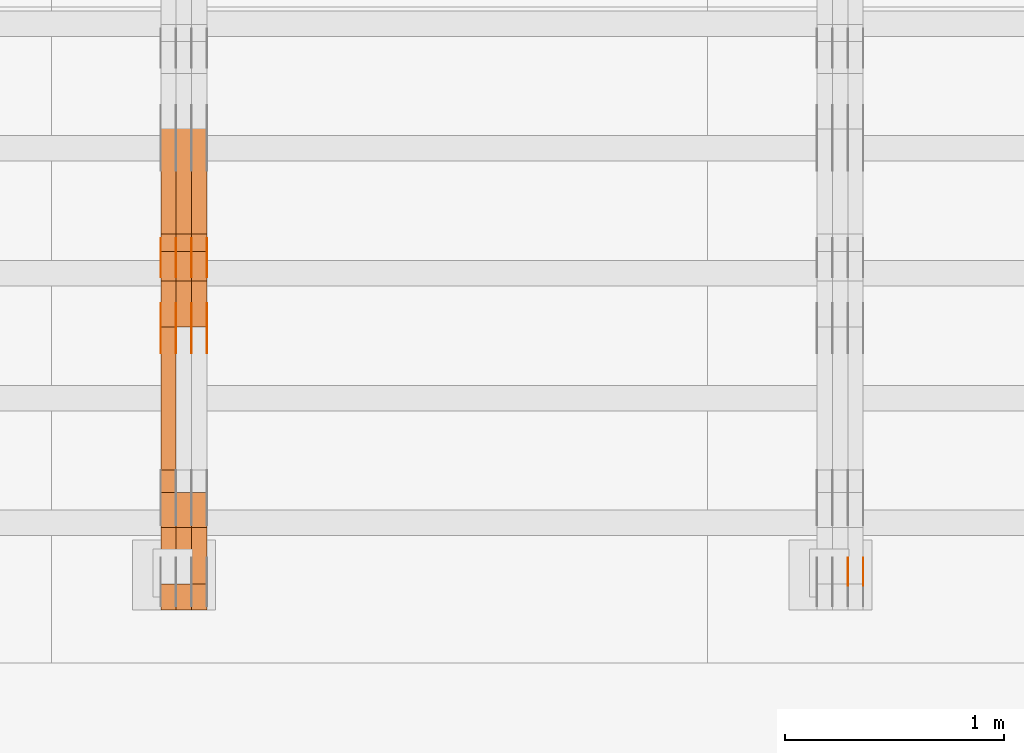
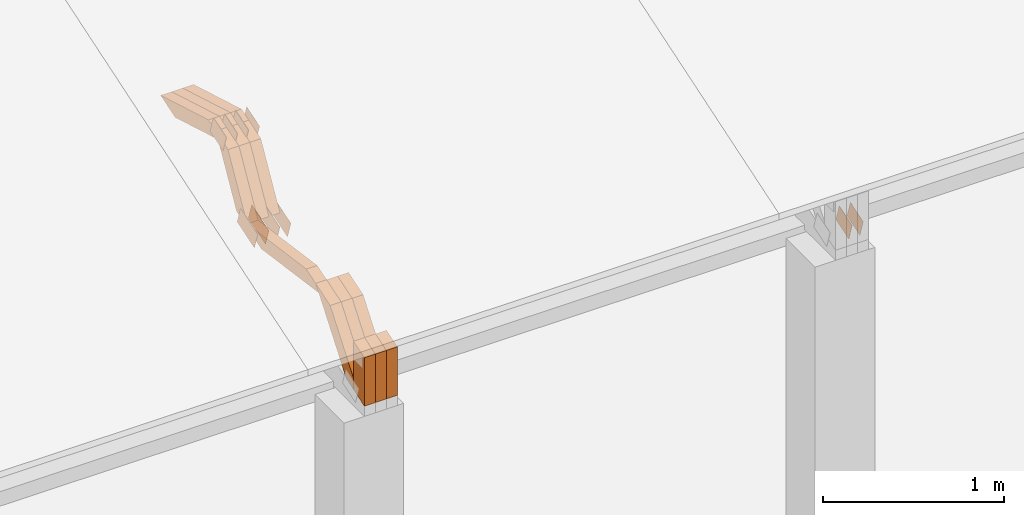
# One storey, part 247 of 385: 28 proxies.
"""IFC2X3 building model written with IfcOpenShell, lengths in millimetres."""

import ifcopenshell
import ifcopenshell.guid

model = None  # the IFC model being written
_history = None  # IfcOwnerHistory: only IFC2X3 demands one
_inside = {}  # id of a spatial element -> (the spatial element, [elements in it])
_under = {}  # id of a project, library or spatial element -> (it, [spatial elements below it])
_declared = {}  # id of a project -> (the project, [libraries it declares])
_typed = {}  # id of a type object -> (the type object, [elements of that type])
_made_of = {}  # id of a material, layer set ... -> (it, [elements and type objects made of it])


def new_model(schema):
    """Start an empty IFC model of exactly this schema.

    Asked for "IFC4X3", IfcOpenShell would pick the latest addendum, in which some entities
    have other attributes; the version numbers below select the first issue.
    IFC2X3 requires an IfcOwnerHistory on every rooted entity: one is made here for all.
    """
    global model, _history
    if schema == "IFC4X3":
        model = ifcopenshell.file(schema_version=(4, 3, 0, 0))
    else:
        model = ifcopenshell.file(schema=schema)
    _inside.clear()
    _under.clear()
    _declared.clear()
    _typed.clear()
    _made_of.clear()
    _history = None
    if model.schema == "IFC2X3":
        org = make("IfcOrganization", Name="unknown")
        user = make(
            "IfcPersonAndOrganization",
            ThePerson=make("IfcPerson", FamilyName="unknown"),
            TheOrganization=org,
        )
        app = make(
            "IfcApplication",
            ApplicationDeveloper=org,
            Version="unknown",
            ApplicationFullName="unknown",
            ApplicationIdentifier="unknown",
        )
        _history = make(
            "IfcOwnerHistory",
            OwningUser=user,
            OwningApplication=app,
            ChangeAction="ADDED",
            CreationDate=0,
        )
    return model


def make(cls, **values):
    """One entity of the class cls with the attributes given. An attribute that is None is left unset."""
    return model.create_entity(
        cls, **{name: value for name, value in values.items() if value is not None}
    )


def entity(cls, *values):
    """Any entity or typed value of the class cls, its attributes in the order of the schema. None: left unset."""
    e = model.create_entity(cls)
    for i, value in enumerate(values):
        if value is not None:
            e[i] = value
    return e


def rooted(cls, **values):
    """An entity with a GlobalId (a new one), such as an element, a storey or a relation."""
    return make(cls, GlobalId=ifcopenshell.guid.new(), OwnerHistory=_history, **values)


def si_unit(unit_type, name, prefix=None):
    """IfcSIUnit, for example si_unit("LENGTHUNIT", "METRE", prefix="MILLI")."""
    return make("IfcSIUnit", UnitType=unit_type, Prefix=prefix, Name=name)


def converted_unit(unit_type, name, factor, base, dimensions=None, offset=None):
    """IfcConversionBasedUnit, such as the inch: factor (a typed value) times the base unit."""
    return make(
        "IfcConversionBasedUnit"
        if offset is None
        else "IfcConversionBasedUnitWithOffset",
        ConversionOffset=offset,
        Dimensions=None
        if dimensions is None
        else entity("IfcDimensionalExponents", *dimensions),
        UnitType=unit_type,
        Name=name,
        ConversionFactor=make(
            "IfcMeasureWithUnit", ValueComponent=factor, UnitComponent=base
        ),
    )


def derived_unit(unit_type, elements):
    """IfcDerivedUnit: a product of units, each with its exponent."""
    return make(
        "IfcDerivedUnit",
        Elements=[
            make("IfcDerivedUnitElement", Unit=unit, Exponent=power)
            for unit, power in elements
        ],
        UnitType=unit_type,
    )


def assignment(units):
    """IfcUnitAssignment: the units of a project."""
    return None if units is None else make("IfcUnitAssignment", Units=units)


def point(xyz):
    """IfcCartesianPoint."""
    return None if xyz is None else make("IfcCartesianPoint", Coordinates=xyz)


def direction(xyz):
    """IfcDirection."""
    return None if xyz is None else make("IfcDirection", DirectionRatios=xyz)


def frame(location, z_axis=None, x_axis=None):
    """IfcAxis2Placement3D, a coordinate frame: its origin and axes. An axis left out is left unset."""
    return make(
        "IfcAxis2Placement3D",
        Location=point(location),
        Axis=direction(z_axis),
        RefDirection=direction(x_axis),
    )


def origin():
    """The frame at (0, 0, 0) with its axes left unset."""
    return frame((0.0, 0.0, 0.0))


def place(relative_to, where):
    """IfcLocalPlacement: puts the frame where relative to a parent placement (None: the world)."""
    return make(
        "IfcLocalPlacement", PlacementRelTo=relative_to, RelativePlacement=where
    )


def context(
    kind, dimensions, precision=None, world=None, true_north=None, identifier=None
):
    """IfcGeometricRepresentationContext, for example the 3D "Model" context."""
    return make(
        "IfcGeometricRepresentationContext",
        ContextIdentifier=identifier,
        ContextType=kind,
        CoordinateSpaceDimension=dimensions,
        Precision=precision,
        WorldCoordinateSystem=world,
        TrueNorth=true_north,
    )


def subcontext(parent, identifier, kind, view, scale=None):
    """IfcGeometricRepresentationSubContext, for example "Body" below "Model"."""
    return make(
        "IfcGeometricRepresentationSubContext",
        ContextIdentifier=identifier,
        ContextType=kind,
        ParentContext=parent,
        TargetScale=scale,
        TargetView=view,
    )


def project(units=None, contexts=None):
    """IfcProject with its units and contexts."""
    return rooted(
        "IfcProject",
        Name="project",
        RepresentationContexts=contexts,
        UnitsInContext=assignment(units),
    )


def spatial(cls, under=None, at=None, **own):
    """A site, building, storey or space (cls), placed at a placement, below another one or the project."""
    s = rooted(cls, ObjectPlacement=at, **own)
    if under is not None:
        _under.setdefault(under.id(), (under, []))[1].append(s)
    return s


def polyline(points):
    """IfcPolyline through the points."""
    return make("IfcPolyline", Points=[point(p) for p in points])


def outline(outer, holes=None, kind="AREA"):
    """IfcArbitraryClosedProfileDef: a profile drawn as a closed curve; with holes, ...WithVoids."""
    if holes is None:
        return make("IfcArbitraryClosedProfileDef", ProfileType=kind, OuterCurve=outer)
    return make(
        "IfcArbitraryProfileDefWithVoids",
        ProfileType=kind,
        OuterCurve=outer,
        InnerCurves=holes,
    )


def extrude(swept, where, along, depth):
    """IfcExtrudedAreaSolid: the profile swept, set in the frame where, extruded along a direction by depth."""
    return make(
        "IfcExtrudedAreaSolid",
        SweptArea=swept,
        Position=where,
        ExtrudedDirection=direction(along),
        Depth=depth,
    )


def shape(context_of_items, identifier, shape_type, items):
    """IfcShapeRepresentation: the items that make up one representation, for example the "Body"."""
    return make(
        "IfcShapeRepresentation",
        ContextOfItems=context_of_items,
        RepresentationIdentifier=identifier,
        RepresentationType=shape_type,
        Items=items,
    )


def source(mapping_origin, context_of_items, identifier, shape_type, items):
    """IfcRepresentationMap: a shape defined once, which mapped items show again and again."""
    return make(
        "IfcRepresentationMap",
        MappingOrigin=mapping_origin,
        MappedRepresentation=shape(context_of_items, identifier, shape_type, items),
    )


def transform(
    local_origin,
    x_axis=None,
    y_axis=None,
    z_axis=None,
    scale=None,
    scale2=None,
    scale3=None,
    uniform=True,
):
    """IfcCartesianTransformationOperator3D, or its non-uniform kind. x_axis, y_axis, z_axis: its Axis1, 2, 3."""
    if uniform:
        return make(
            "IfcCartesianTransformationOperator3D",
            Axis1=direction(x_axis),
            Axis2=direction(y_axis),
            LocalOrigin=point(local_origin),
            Scale=scale,
            Axis3=direction(z_axis),
        )
    return make(
        "IfcCartesianTransformationOperator3DnonUniform",
        Axis1=direction(x_axis),
        Axis2=direction(y_axis),
        LocalOrigin=point(local_origin),
        Scale=scale,
        Axis3=direction(z_axis),
        Scale2=scale2,
        Scale3=scale3,
    )


def mapped(mapping_source, mapping_target):
    """IfcMappedItem: shows the shape of a source again, moved by a transform."""
    return make(
        "IfcMappedItem", MappingSource=mapping_source, MappingTarget=mapping_target
    )


def material(Name=None, Category=None):
    """IfcMaterial."""
    return make("IfcMaterial", Name=Name, Category=Category)


def made_of(thing, what):
    """Note that an element or type object is made of a material, layer set ...; save() writes the relation."""
    if what is not None:
        _made_of.setdefault(what.id(), (what, []))[1].append(thing)
    return thing


def type_object(cls, material=None, **own):
    """A type object (cls), such as IfcWallType, which elements share."""
    return made_of(rooted(cls, **own), material)


def type_shapes(of_type, sources):
    """Give a type object the sources (RepresentationMaps) that its elements show as mapped items."""
    of_type.RepresentationMaps = sources


def element(
    cls,
    number,
    at=None,
    inside=None,
    cuts=None,
    type_object=None,
    material=None,
    context=None,
    identifier="Body",
    shape_type=None,
    held_by="IfcProductDefinitionShape",
    body=None,
    shapes=None,
    **own,
):
    """One element of the class cls, such as IfcWall. Its Tag is "e" and its number.

    at: its placement. inside: the storey or other place that contains it. cuts: it is an
    opening in that element (IfcRelVoidsElement). A single representation is given by context,
    identifier, shape_type and body (its items); several are given by shapes. held_by: the class
    of the entity that holds the representations. save() writes the other relations.
    """
    e = rooted(cls, Tag="e%d" % number, ObjectPlacement=at, **own)
    if body is not None:
        shapes = [shape(context, identifier, shape_type, body)]
    if shapes is not None:
        e.Representation = make(held_by, Representations=shapes)
    if inside is not None:
        _inside.setdefault(inside.id(), (inside, []))[1].append(e)
    if cuts is not None:
        rooted(
            "IfcRelVoidsElement", RelatingBuildingElement=cuts, RelatedOpeningElement=e
        )
    if type_object is not None:
        _typed.setdefault(type_object.id(), (type_object, []))[1].append(e)
    return made_of(e, material)


def aggregate(whole, parts):
    """IfcRelAggregates: a whole, such as a stair, and the parts it consists of."""
    return rooted("IfcRelAggregates", RelatingObject=whole, RelatedObjects=parts)


def save(model, path):
    """Write the relations noted so far, then the file.

    IfcRelAggregates (storeys below a building ...), IfcRelContainedInSpatialStructure (elements
    in a storey), IfcRelDefinesByType, IfcRelAssociatesMaterial and IfcRelDeclares: one each for
    every whole, place, type object, material and project.
    """
    for whole, parts in _under.values():
        aggregate(whole, parts)
    for where, things in _inside.values():
        rooted(
            "IfcRelContainedInSpatialStructure",
            RelatedElements=things,
            RelatingStructure=where,
        )
    for kind, things in _typed.values():
        rooted("IfcRelDefinesByType", RelatedObjects=things, RelatingType=kind)
    for what, things in _made_of.values():
        rooted("IfcRelAssociatesMaterial", RelatedObjects=things, RelatingMaterial=what)
    for by, libraries in _declared.values():
        rooted("IfcRelDeclares", RelatingContext=by, RelatedDefinitions=libraries)
    model.write(path)


model = new_model("IFC2X3")

# Units and contexts
model_context = context("Model", 3, precision=0.01, world=origin(), true_north=direction((6.12303176911189e-17, 1.0)))
body_context = subcontext(model_context, "Body", "Model", "MODEL_VIEW")
ifc_project = project(units=[si_unit("LENGTHUNIT", "METRE", prefix="MILLI"), si_unit("AREAUNIT", "SQUARE_METRE"), si_unit("VOLUMEUNIT", "CUBIC_METRE"), converted_unit("PLANEANGLEUNIT", "DEGREE", entity("IfcRatioMeasure", 0.0174532925199433), si_unit("PLANEANGLEUNIT", "RADIAN"), dimensions=[0, 0, 0, 0, 0, 0, 0]), si_unit("MASSUNIT", "GRAM", prefix="KILO"), derived_unit("MASSDENSITYUNIT", [(si_unit("MASSUNIT", "GRAM", prefix="KILO"), 1), (si_unit("LENGTHUNIT", "METRE"), -3)]), si_unit("TIMEUNIT", "SECOND"), si_unit("FREQUENCYUNIT", "HERTZ"), si_unit("THERMODYNAMICTEMPERATUREUNIT", "DEGREE_CELSIUS"), derived_unit("THERMALTRANSMITTANCEUNIT", [(si_unit("MASSUNIT", "GRAM", prefix="KILO"), 1), (si_unit("THERMODYNAMICTEMPERATUREUNIT", "KELVIN"), -1), (si_unit("TIMEUNIT", "SECOND"), -3)]), derived_unit("VOLUMETRICFLOWRATEUNIT", [(si_unit("LENGTHUNIT", "METRE"), 3), (si_unit("TIMEUNIT", "SECOND"), -1)]), si_unit("ELECTRICCURRENTUNIT", "AMPERE"), si_unit("ELECTRICVOLTAGEUNIT", "VOLT"), si_unit("POWERUNIT", "WATT"), si_unit("FORCEUNIT", "NEWTON", prefix="KILO"), si_unit("ILLUMINANCEUNIT", "LUX"), si_unit("LUMINOUSFLUXUNIT", "LUMEN"), si_unit("LUMINOUSINTENSITYUNIT", "CANDELA"), derived_unit("USERDEFINED", [(si_unit("MASSUNIT", "GRAM", prefix="KILO"), -1), (si_unit("LENGTHUNIT", "METRE"), -2), (si_unit("TIMEUNIT", "SECOND"), 3), (si_unit("LUMINOUSFLUXUNIT", "LUMEN"), 1)]), derived_unit("LINEARVELOCITYUNIT", [(si_unit("LENGTHUNIT", "METRE"), 1), (si_unit("TIMEUNIT", "SECOND"), -1)]), si_unit("PRESSUREUNIT", "PASCAL"), derived_unit("USERDEFINED", [(si_unit("LENGTHUNIT", "METRE"), -2), (si_unit("MASSUNIT", "GRAM", prefix="KILO"), 1), (si_unit("TIMEUNIT", "SECOND"), -2)])], contexts=[model_context])

# Site, building, storey
site_placement = place(None, origin())
site = spatial("IfcSite", under=ifc_project, at=site_placement, CompositionType="ELEMENT")
building_placement = place(site_placement, origin())
building = spatial("IfcBuilding", under=site, at=building_placement, CompositionType="ELEMENT")
storey_placement = place(building_placement, origin())
storey = spatial("IfcBuildingStorey", under=building, at=storey_placement, Name="Default", CompositionType="ELEMENT", Elevation=0.0)

# Proxies
ifc_material_1 = material(Name="IfcSurfaceStyle #477756")
building_element_proxy_type_1 = type_object("IfcBuildingElementProxyType", PredefinedType="NOTDEFINED", material=ifc_material_1)
shared_shape_1 = source(origin(), body_context, "Body", "SweptSolid", [
    extrude(outline(polyline([(-74.999865408764, -60.0000379172698), (74.9998729365771, -60.0000379172698), (74.9998642299588, 60.0000379172698), (-74.9998717577719, 60.0000379172698), (-74.999865408764, -60.0000379172698)])), frame((75.0005044383734, 60.0001679035349, 0.0), z_axis=(0.0, 0.0, 1.0), x_axis=(-1.0, 0.0, 0.0)), (0.0, 0.0, 1.0), 1.3),
])
type_shapes(building_element_proxy_type_1, [shared_shape_1])
proxy_1_placement = place(building_placement, frame((39386.3, 2998.66143710398, 150.423871180894), z_axis=(-1.0, 0.0, 0.0), x_axis=(0.0, 0.951056516295124, 0.309016994375039)))
element("IfcBuildingElementProxy", 1, at=proxy_1_placement, inside=storey, type_object=building_element_proxy_type_1, material=ifc_material_1, context=body_context, shape_type="MappedRepresentation", body=[
    mapped(shared_shape_1, transform((0.0, 0.0, 0.0), scale=1.0)),
])
ifc_material_2 = material(Name="IfcSurfaceStyle #477699")
building_element_proxy_type_2 = type_object("IfcBuildingElementProxyType", PredefinedType="NOTDEFINED", material=ifc_material_2)
shared_shape_2 = source(origin(), body_context, "Body", "SweptSolid", [
    extrude(outline(polyline([(-74.999865408764, -60.0000379172698), (74.9998729365771, -60.0000379172698), (74.9998642299588, 60.0000379172698), (-74.9998717577719, 60.0000379172698), (-74.999865408764, -60.0000379172698)])), frame((75.0005044383734, 60.0001679035349, 0.0), z_axis=(0.0, 0.0, 1.0), x_axis=(-1.0, 0.0, 0.0)), (0.0, 0.0, 1.0), 1.3),
])
type_shapes(building_element_proxy_type_2, [shared_shape_2])
proxy_2_placement = place(building_placement, frame((39315.0, 2998.66143710398, 150.423871180894), z_axis=(-1.0, 0.0, 0.0), x_axis=(0.0, 0.951056516295124, 0.309016994375039)))
element("IfcBuildingElementProxy", 2, at=proxy_2_placement, inside=storey, type_object=building_element_proxy_type_2, material=ifc_material_2, context=body_context, shape_type="MappedRepresentation", body=[
    mapped(shared_shape_2, transform((0.0, 0.0, 0.0), scale=1.0)),
])
ifc_material_3 = material(Name="IfcSurfaceStyle #477642")
building_element_proxy_type_3 = type_object("IfcBuildingElementProxyType", PredefinedType="NOTDEFINED", material=ifc_material_3)
shared_shape_3 = source(origin(), body_context, "Body", "SweptSolid", [
    extrude(outline(polyline([(-74.999865408764, -60.0000379172698), (74.9998729365771, -60.0000379172698), (74.9998642299588, 60.0000379172698), (-74.9998717577719, 60.0000379172698), (-74.999865408764, -60.0000379172698)])), frame((75.0005044383734, 60.0001679035349, 0.0), z_axis=(0.0, 0.0, 1.0), x_axis=(-1.0, 0.0, 0.0)), (0.0, 0.0, 1.0), 1.3),
])
type_shapes(building_element_proxy_type_3, [shared_shape_3])
proxy_3_placement = place(building_placement, frame((39316.3, 2998.66143710398, 150.423871180894), z_axis=(-1.0, 0.0, 0.0), x_axis=(0.0, 0.951056516295124, 0.309016994375039)))
element("IfcBuildingElementProxy", 3, at=proxy_3_placement, inside=storey, type_object=building_element_proxy_type_3, material=ifc_material_3, context=body_context, shape_type="MappedRepresentation", body=[
    mapped(shared_shape_3, transform((0.0, 0.0, 0.0), scale=1.0)),
])
ifc_material_4 = material(Name="IfcSurfaceStyle #442982")
building_element_proxy_type_4 = type_object("IfcBuildingElementProxyType", PredefinedType="NOTDEFINED", material=ifc_material_4)
shared_shape_4 = source(origin(), body_context, "Body", "SweptSolid", [
    extrude(outline(polyline([(-99.9998204243802, -60.000067376167), (99.9998338462265, -60.000067376167), (99.9998204243802, 60.000067376167), (-99.9998338462265, 60.000067376167), (-99.9998204243802, -60.000067376167)])), frame((100.000602015329, 60.0001864986889, 0.0), z_axis=(0.0, 0.0, 1.0), x_axis=(-1.0, 0.0, 0.0)), (0.0, 0.0, 1.0), 1.3),
])
type_shapes(building_element_proxy_type_4, [shared_shape_4])
proxy_4_placement = place(building_placement, frame((36386.3, 4114.85465165112, 513.097031388771), z_axis=(-1.0, 0.0, 0.0), x_axis=(0.0, 0.951056516295124, 0.309016994375039)))
element("IfcBuildingElementProxy", 4, at=proxy_4_placement, inside=storey, type_object=building_element_proxy_type_4, material=ifc_material_4, context=body_context, shape_type="MappedRepresentation", body=[
    mapped(shared_shape_4, transform((0.0, 0.0, 0.0), scale=1.0)),
])
ifc_material_5 = material(Name="IfcSurfaceStyle #442925")
building_element_proxy_type_5 = type_object("IfcBuildingElementProxyType", PredefinedType="NOTDEFINED", material=ifc_material_5)
shared_shape_5 = source(origin(), body_context, "Body", "SweptSolid", [
    extrude(outline(polyline([(-99.9998204243802, -60.000067376167), (99.9998338462265, -60.000067376167), (99.9998204243802, 60.000067376167), (-99.9998338462265, 60.000067376167), (-99.9998204243802, -60.000067376167)])), frame((100.000602015329, 60.0001864986889, 0.0), z_axis=(0.0, 0.0, 1.0), x_axis=(-1.0, 0.0, 0.0)), (0.0, 0.0, 1.0), 1.3),
])
type_shapes(building_element_proxy_type_5, [shared_shape_5])
proxy_5_placement = place(building_placement, frame((36315.0, 4114.85465165112, 513.097031388771), z_axis=(-1.0, 0.0, 0.0), x_axis=(0.0, 0.951056516295124, 0.309016994375039)))
element("IfcBuildingElementProxy", 5, at=proxy_5_placement, inside=storey, type_object=building_element_proxy_type_5, material=ifc_material_5, context=body_context, shape_type="MappedRepresentation", body=[
    mapped(shared_shape_5, transform((0.0, 0.0, 0.0), scale=1.0)),
])
ifc_material_6 = material(Name="IfcSurfaceStyle #442868")
building_element_proxy_type_6 = type_object("IfcBuildingElementProxyType", PredefinedType="NOTDEFINED", material=ifc_material_6)
shared_shape_6 = source(origin(), body_context, "Body", "SweptSolid", [
    extrude(outline(polyline([(-99.9998204243802, -60.000067376167), (99.9998338462265, -60.000067376167), (99.9998204243802, 60.000067376167), (-99.9998338462265, 60.000067376167), (-99.9998204243802, -60.000067376167)])), frame((100.000602015329, 60.0001864986889, 0.0), z_axis=(0.0, 0.0, 1.0), x_axis=(-1.0, 0.0, 0.0)), (0.0, 0.0, 1.0), 1.3),
])
type_shapes(building_element_proxy_type_6, [shared_shape_6])
proxy_6_placement = place(building_placement, frame((36316.3, 4114.85465165112, 513.097031388771), z_axis=(-1.0, 0.0, 0.0), x_axis=(0.0, 0.951056516295124, 0.309016994375039)))
element("IfcBuildingElementProxy", 6, at=proxy_6_placement, inside=storey, type_object=building_element_proxy_type_6, material=ifc_material_6, context=body_context, shape_type="MappedRepresentation", body=[
    mapped(shared_shape_6, transform((0.0, 0.0, 0.0), scale=1.0)),
])
ifc_material_7 = material(Name="IfcSurfaceStyle #442811")
building_element_proxy_type_7 = type_object("IfcBuildingElementProxyType", PredefinedType="NOTDEFINED", material=ifc_material_7)
shared_shape_7 = source(origin(), body_context, "Body", "SweptSolid", [
    extrude(outline(polyline([(-99.9998204243802, -60.000067376167), (99.9998338462265, -60.000067376167), (99.9998204243802, 60.000067376167), (-99.9998338462265, 60.000067376167), (-99.9998204243802, -60.000067376167)])), frame((100.000602015329, 60.0001864986889, 0.0), z_axis=(0.0, 0.0, 1.0), x_axis=(-1.0, 0.0, 0.0)), (0.0, 0.0, 1.0), 1.29999999999998),
])
type_shapes(building_element_proxy_type_7, [shared_shape_7])
proxy_7_placement = place(building_placement, frame((36245.0, 4114.85465165112, 513.097031388771), z_axis=(-1.0, 0.0, 0.0), x_axis=(0.0, 0.951056516295124, 0.309016994375039)))
element("IfcBuildingElementProxy", 7, at=proxy_7_placement, inside=storey, type_object=building_element_proxy_type_7, material=ifc_material_7, context=body_context, shape_type="MappedRepresentation", body=[
    mapped(shared_shape_7, transform((0.0, 0.0, 0.0), scale=1.0)),
])
ifc_material_8 = material(Name="IfcSurfaceStyle #442754")
building_element_proxy_type_8 = type_object("IfcBuildingElementProxyType", PredefinedType="NOTDEFINED", material=ifc_material_8)
shared_shape_8 = source(origin(), body_context, "Body", "SweptSolid", [
    extrude(outline(polyline([(-99.9998204243802, -60.000067376167), (99.9998338462265, -60.000067376167), (99.9998204243802, 60.000067376167), (-99.9998338462265, 60.000067376167), (-99.9998204243802, -60.000067376167)])), frame((100.000602015329, 60.0001864986889, 0.0), z_axis=(0.0, 0.0, 1.0), x_axis=(-1.0, 0.0, 0.0)), (0.0, 0.0, 1.0), 1.29999999999998),
])
type_shapes(building_element_proxy_type_8, [shared_shape_8])
proxy_8_placement = place(building_placement, frame((36246.3, 4114.85465165112, 513.097031388771), z_axis=(-1.0, 0.0, 0.0), x_axis=(0.0, 0.951056516295124, 0.309016994375039)))
element("IfcBuildingElementProxy", 8, at=proxy_8_placement, inside=storey, type_object=building_element_proxy_type_8, material=ifc_material_8, context=body_context, shape_type="MappedRepresentation", body=[
    mapped(shared_shape_8, transform((0.0, 0.0, 0.0), scale=1.0)),
])
ifc_material_9 = material(Name="IfcSurfaceStyle #442697")
building_element_proxy_type_9 = type_object("IfcBuildingElementProxyType", PredefinedType="NOTDEFINED", material=ifc_material_9)
shared_shape_9 = source(origin(), body_context, "Body", "SweptSolid", [
    extrude(outline(polyline([(-99.9998204243802, -60.000067376167), (99.9998338462265, -60.000067376167), (99.9998204243802, 60.000067376167), (-99.9998338462265, 60.000067376167), (-99.9998204243802, -60.000067376167)])), frame((100.000602015329, 60.0001864986889, 0.0), z_axis=(0.0, 0.0, 1.0), x_axis=(-1.0, 0.0, 0.0)), (0.0, 0.0, 1.0), 1.29999999999999),
])
type_shapes(building_element_proxy_type_9, [shared_shape_9])
proxy_9_placement = place(building_placement, frame((36175.0, 4114.85465165112, 513.097031388771), z_axis=(-1.0, 0.0, 0.0), x_axis=(0.0, 0.951056516295124, 0.309016994375039)))
element("IfcBuildingElementProxy", 9, at=proxy_9_placement, inside=storey, type_object=building_element_proxy_type_9, material=ifc_material_9, context=body_context, shape_type="MappedRepresentation", body=[
    mapped(shared_shape_9, transform((0.0, 0.0, 0.0), scale=1.0)),
])
ifc_material_10 = material(Name="IfcSurfaceStyle #435800")
building_element_proxy_type_10 = type_object("IfcBuildingElementProxyType", PredefinedType="NOTDEFINED", material=ifc_material_10)
shared_shape_10 = source(origin(), body_context, "Body", "SweptSolid", [
    extrude(outline(polyline([(-74.999865998172, -60.0000306612919), (74.999869989555, -60.0000306612919), (74.999865998172, 60.0000306612919), (-74.999869989555, 60.0000306612919), (-74.999865998172, -60.0000306612919)])), frame((75.0006726017528, 60.0001996460842, 0.0), z_axis=(0.0, 0.0, 1.0), x_axis=(-1.0, 0.0, 0.0)), (0.0, 0.0, 1.0), 1.3),
])
type_shapes(building_element_proxy_type_10, [shared_shape_10])
proxy_10_placement = place(building_placement, frame((36386.3, 4460.38978242656, 957.314497110567), z_axis=(-1.0, 0.0, 0.0), x_axis=(0.0, 0.951056516295154, 0.309016994374948)))
element("IfcBuildingElementProxy", 10, at=proxy_10_placement, inside=storey, type_object=building_element_proxy_type_10, material=ifc_material_10, context=body_context, shape_type="MappedRepresentation", body=[
    mapped(shared_shape_10, transform((0.0, 0.0, 0.0), scale=1.0)),
])
ifc_material_11 = material(Name="IfcSurfaceStyle #435743")
building_element_proxy_type_11 = type_object("IfcBuildingElementProxyType", PredefinedType="NOTDEFINED", material=ifc_material_11)
shared_shape_11 = source(origin(), body_context, "Body", "SweptSolid", [
    extrude(outline(polyline([(-74.999865998172, -60.0000306612919), (74.999869989555, -60.0000306612919), (74.999865998172, 60.0000306612919), (-74.999869989555, 60.0000306612919), (-74.999865998172, -60.0000306612919)])), frame((75.0006726017528, 60.0001996460842, 0.0), z_axis=(0.0, 0.0, 1.0), x_axis=(-1.0, 0.0, 0.0)), (0.0, 0.0, 1.0), 1.3),
])
type_shapes(building_element_proxy_type_11, [shared_shape_11])
proxy_11_placement = place(building_placement, frame((36315.0, 4460.38978242656, 957.314497110567), z_axis=(-1.0, 0.0, 0.0), x_axis=(0.0, 0.951056516295154, 0.309016994374948)))
element("IfcBuildingElementProxy", 11, at=proxy_11_placement, inside=storey, type_object=building_element_proxy_type_11, material=ifc_material_11, context=body_context, shape_type="MappedRepresentation", body=[
    mapped(shared_shape_11, transform((0.0, 0.0, 0.0), scale=1.0)),
])
ifc_material_12 = material(Name="IfcSurfaceStyle #435686")
building_element_proxy_type_12 = type_object("IfcBuildingElementProxyType", PredefinedType="NOTDEFINED", material=ifc_material_12)
shared_shape_12 = source(origin(), body_context, "Body", "SweptSolid", [
    extrude(outline(polyline([(-74.999865998172, -60.0000306612919), (74.999869989555, -60.0000306612919), (74.999865998172, 60.0000306612919), (-74.999869989555, 60.0000306612919), (-74.999865998172, -60.0000306612919)])), frame((75.0006726017528, 60.0001996460842, 0.0), z_axis=(0.0, 0.0, 1.0), x_axis=(-1.0, 0.0, 0.0)), (0.0, 0.0, 1.0), 1.3),
])
type_shapes(building_element_proxy_type_12, [shared_shape_12])
proxy_12_placement = place(building_placement, frame((36316.3, 4460.38978242656, 957.314497110567), z_axis=(-1.0, 0.0, 0.0), x_axis=(0.0, 0.951056516295154, 0.309016994374948)))
element("IfcBuildingElementProxy", 12, at=proxy_12_placement, inside=storey, type_object=building_element_proxy_type_12, material=ifc_material_12, context=body_context, shape_type="MappedRepresentation", body=[
    mapped(shared_shape_12, transform((0.0, 0.0, 0.0), scale=1.0)),
])
ifc_material_13 = material(Name="IfcSurfaceStyle #435629")
building_element_proxy_type_13 = type_object("IfcBuildingElementProxyType", PredefinedType="NOTDEFINED", material=ifc_material_13)
shared_shape_13 = source(origin(), body_context, "Body", "SweptSolid", [
    extrude(outline(polyline([(-74.999865998172, -60.0000306612919), (74.999869989555, -60.0000306612919), (74.999865998172, 60.0000306612919), (-74.999869989555, 60.0000306612919), (-74.999865998172, -60.0000306612919)])), frame((75.0006726017528, 60.0001996460842, 0.0), z_axis=(0.0, 0.0, 1.0), x_axis=(-1.0, 0.0, 0.0)), (0.0, 0.0, 1.0), 1.29999999999999),
])
type_shapes(building_element_proxy_type_13, [shared_shape_13])
proxy_13_placement = place(building_placement, frame((36245.0, 4460.38978242656, 957.314497110567), z_axis=(-1.0, 0.0, 0.0), x_axis=(0.0, 0.951056516295154, 0.309016994374948)))
element("IfcBuildingElementProxy", 13, at=proxy_13_placement, inside=storey, type_object=building_element_proxy_type_13, material=ifc_material_13, context=body_context, shape_type="MappedRepresentation", body=[
    mapped(shared_shape_13, transform((0.0, 0.0, 0.0), scale=1.0)),
])
ifc_material_14 = material(Name="IfcSurfaceStyle #435572")
building_element_proxy_type_14 = type_object("IfcBuildingElementProxyType", PredefinedType="NOTDEFINED", material=ifc_material_14)
shared_shape_14 = source(origin(), body_context, "Body", "SweptSolid", [
    extrude(outline(polyline([(-74.999865998172, -60.0000306612919), (74.999869989555, -60.0000306612919), (74.999865998172, 60.0000306612919), (-74.999869989555, 60.0000306612919), (-74.999865998172, -60.0000306612919)])), frame((75.0006726017528, 60.0001996460842, 0.0), z_axis=(0.0, 0.0, 1.0), x_axis=(-1.0, 0.0, 0.0)), (0.0, 0.0, 1.0), 1.29999999999999),
])
type_shapes(building_element_proxy_type_14, [shared_shape_14])
proxy_14_placement = place(building_placement, frame((36246.3, 4460.38978242656, 957.314497110567), z_axis=(-1.0, 0.0, 0.0), x_axis=(0.0, 0.951056516295154, 0.309016994374948)))
element("IfcBuildingElementProxy", 14, at=proxy_14_placement, inside=storey, type_object=building_element_proxy_type_14, material=ifc_material_14, context=body_context, shape_type="MappedRepresentation", body=[
    mapped(shared_shape_14, transform((0.0, 0.0, 0.0), scale=1.0)),
])
ifc_material_15 = material(Name="IfcSurfaceStyle #435515")
building_element_proxy_type_15 = type_object("IfcBuildingElementProxyType", PredefinedType="NOTDEFINED", material=ifc_material_15)
shared_shape_15 = source(origin(), body_context, "Body", "SweptSolid", [
    extrude(outline(polyline([(-74.999865998172, -60.0000306612919), (74.999869989555, -60.0000306612919), (74.999865998172, 60.0000306612919), (-74.999869989555, 60.0000306612919), (-74.999865998172, -60.0000306612919)])), frame((75.0006726017528, 60.0001996460842, 0.0), z_axis=(0.0, 0.0, 1.0), x_axis=(-1.0, 0.0, 0.0)), (0.0, 0.0, 1.0), 1.29999999999999),
])
type_shapes(building_element_proxy_type_15, [shared_shape_15])
proxy_15_placement = place(building_placement, frame((36175.0, 4460.38978242656, 957.314497110567), z_axis=(-1.0, 0.0, 0.0), x_axis=(0.0, 0.951056516295154, 0.309016994374948)))
element("IfcBuildingElementProxy", 15, at=proxy_15_placement, inside=storey, type_object=building_element_proxy_type_15, material=ifc_material_15, context=body_context, shape_type="MappedRepresentation", body=[
    mapped(shared_shape_15, transform((0.0, 0.0, 0.0), scale=1.0)),
])
ifc_material_16 = material(Name="IfcSurfaceStyle #423272")
building_element_proxy_type_16 = type_object("IfcBuildingElementProxyType", Name="T1-W12 423270", PredefinedType="NOTDEFINED", material=ifc_material_16)
shared_shape_16 = source(origin(), body_context, "Body", "SweptSolid", [
    extrude(outline(polyline([(-249.405625983165, -47.5001691155616), (243.345753908996, -47.5001691155616), (232.115534842595, 2.39993474701938e-05), (162.527010966644, 47.5001571158879), (-388.58267373507, 47.5001571158879), (-249.405625983165, -47.5001691155616)])), frame((243.345867653852, 47.5001571158879, 0.0), z_axis=(0.0, 0.0, 1.0), x_axis=(-1.0, 0.0, 0.0)), (0.0, 0.0, 1.0), 70.0),
])
type_shapes(building_element_proxy_type_16, [shared_shape_16])
proxy_16_placement = place(building_placement, frame((36385.0, 4581.32698473631, 976.172276753357), z_axis=(-1.0, 0.0, 0.0), x_axis=(0.0, 0.959722067881787, -0.280951156645966)))
element("IfcBuildingElementProxy", 16, at=proxy_16_placement, inside=storey, type_object=building_element_proxy_type_16, material=ifc_material_16, Name="T1-W12", context=body_context, shape_type="MappedRepresentation", body=[
    mapped(shared_shape_16, transform((0.0, 0.0, 0.0), scale=1.0)),
])
ifc_material_17 = material(Name="IfcSurfaceStyle #423206")
building_element_proxy_type_17 = type_object("IfcBuildingElementProxyType", Name="T1-W12 423204", PredefinedType="NOTDEFINED", material=ifc_material_17)
shared_shape_17 = source(origin(), body_context, "Body", "SweptSolid", [
    extrude(outline(polyline([(-249.405625983165, -47.5001691155616), (243.345753908996, -47.5001691155616), (232.115534842595, 2.39993474701938e-05), (162.527010966644, 47.5001571158879), (-388.58267373507, 47.5001571158879), (-249.405625983165, -47.5001691155616)])), frame((243.345867653852, 47.5001571158879, 0.0), z_axis=(0.0, 0.0, 1.0), x_axis=(-1.0, 0.0, 0.0)), (0.0, 0.0, 1.0), 70.0),
])
type_shapes(building_element_proxy_type_17, [shared_shape_17])
proxy_17_placement = place(building_placement, frame((36315.0, 4581.32698473631, 976.172276753357), z_axis=(-1.0, 0.0, 0.0), x_axis=(0.0, 0.959722067881787, -0.280951156645966)))
element("IfcBuildingElementProxy", 17, at=proxy_17_placement, inside=storey, type_object=building_element_proxy_type_17, material=ifc_material_17, Name="T1-W12", context=body_context, shape_type="MappedRepresentation", body=[
    mapped(shared_shape_17, transform((0.0, 0.0, 0.0), scale=1.0)),
])
ifc_material_18 = material(Name="IfcSurfaceStyle #423140")
building_element_proxy_type_18 = type_object("IfcBuildingElementProxyType", Name="T1-W12 423138", PredefinedType="NOTDEFINED", material=ifc_material_18)
shared_shape_18 = source(origin(), body_context, "Body", "SweptSolid", [
    extrude(outline(polyline([(-249.405625983165, -47.5001691155616), (243.345753908996, -47.5001691155616), (232.115534842595, 2.39993474701938e-05), (162.527010966644, 47.5001571158879), (-388.58267373507, 47.5001571158879), (-249.405625983165, -47.5001691155616)])), frame((243.345867653852, 47.5001571158879, 0.0), z_axis=(0.0, 0.0, 1.0), x_axis=(-1.0, 0.0, 0.0)), (0.0, 0.0, 1.0), 70.0),
])
type_shapes(building_element_proxy_type_18, [shared_shape_18])
proxy_18_placement = place(building_placement, frame((36245.0, 4581.32698473631, 976.172276753357), z_axis=(-1.0, 0.0, 0.0), x_axis=(0.0, 0.959722067881787, -0.280951156645966)))
element("IfcBuildingElementProxy", 18, at=proxy_18_placement, inside=storey, type_object=building_element_proxy_type_18, material=ifc_material_18, Name="T1-W12", context=body_context, shape_type="MappedRepresentation", body=[
    mapped(shared_shape_18, transform((0.0, 0.0, 0.0), scale=1.0)),
])
ifc_material_19 = material(Name="IfcSurfaceStyle #422876")
building_element_proxy_type_19 = type_object("IfcBuildingElementProxyType", Name="T1-W27 422874", PredefinedType="NOTDEFINED", material=ifc_material_19)
shared_shape_19 = source(origin(), body_context, "Body", "SweptSolid", [
    extrude(outline(polyline([(-321.979763159708, -47.49993999164), (138.960018341432, -47.49993999164), (191.013775341887, -0.000473170132329126), (209.87827169492, 47.5001765767061), (-217.872302218531, 47.5001765767062), (-321.979763159708, -47.49993999164)])), frame((209.87827169492, 47.5001765767061, 0.0), z_axis=(0.0, 0.0, 1.0), x_axis=(-1.0, 0.0, 0.0)), (0.0, 0.0, 1.0), 70.0),
])
type_shapes(building_element_proxy_type_19, [shared_shape_19])
proxy_19_placement = place(building_placement, frame((36385.0, 4233.3125, 512.021728515625), z_axis=(-1.0, 0.0, 0.0), x_axis=(0.0, 0.494231057369727, 0.869330582650352)))
element("IfcBuildingElementProxy", 19, at=proxy_19_placement, inside=storey, type_object=building_element_proxy_type_19, material=ifc_material_19, Name="T1-W27", context=body_context, shape_type="MappedRepresentation", body=[
    mapped(shared_shape_19, transform((0.0, 0.0, 0.0), scale=1.0)),
])
ifc_material_20 = material(Name="IfcSurfaceStyle #422810")
building_element_proxy_type_20 = type_object("IfcBuildingElementProxyType", Name="T1-W27 422808", PredefinedType="NOTDEFINED", material=ifc_material_20)
shared_shape_20 = source(origin(), body_context, "Body", "SweptSolid", [
    extrude(outline(polyline([(-321.979763159708, -47.49993999164), (138.960018341432, -47.49993999164), (191.013775341887, -0.000473170132329126), (209.87827169492, 47.5001765767061), (-217.872302218531, 47.5001765767062), (-321.979763159708, -47.49993999164)])), frame((209.87827169492, 47.5001765767061, 0.0), z_axis=(0.0, 0.0, 1.0), x_axis=(-1.0, 0.0, 0.0)), (0.0, 0.0, 1.0), 70.0),
])
type_shapes(building_element_proxy_type_20, [shared_shape_20])
proxy_20_placement = place(building_placement, frame((36315.0, 4233.3125, 512.021728515625), z_axis=(-1.0, 0.0, 0.0), x_axis=(0.0, 0.494231057369727, 0.869330582650352)))
element("IfcBuildingElementProxy", 20, at=proxy_20_placement, inside=storey, type_object=building_element_proxy_type_20, material=ifc_material_20, Name="T1-W27", context=body_context, shape_type="MappedRepresentation", body=[
    mapped(shared_shape_20, transform((0.0, 0.0, 0.0), scale=1.0)),
])
ifc_material_21 = material(Name="IfcSurfaceStyle #422744")
building_element_proxy_type_21 = type_object("IfcBuildingElementProxyType", Name="T1-W27 422742", PredefinedType="NOTDEFINED", material=ifc_material_21)
shared_shape_21 = source(origin(), body_context, "Body", "SweptSolid", [
    extrude(outline(polyline([(-321.979763159708, -47.49993999164), (138.960018341432, -47.49993999164), (191.013775341887, -0.000473170132329126), (209.87827169492, 47.5001765767061), (-217.872302218531, 47.5001765767062), (-321.979763159708, -47.49993999164)])), frame((209.87827169492, 47.5001765767061, 0.0), z_axis=(0.0, 0.0, 1.0), x_axis=(-1.0, 0.0, 0.0)), (0.0, 0.0, 1.0), 70.0),
])
type_shapes(building_element_proxy_type_21, [shared_shape_21])
proxy_21_placement = place(building_placement, frame((36245.0, 4233.3125, 512.021728515625), z_axis=(-1.0, 0.0, 0.0), x_axis=(0.0, 0.494231057369727, 0.869330582650352)))
element("IfcBuildingElementProxy", 21, at=proxy_21_placement, inside=storey, type_object=building_element_proxy_type_21, material=ifc_material_21, Name="T1-W27", context=body_context, shape_type="MappedRepresentation", body=[
    mapped(shared_shape_21, transform((0.0, 0.0, 0.0), scale=1.0)),
])
ifc_material_22 = material(Name="IfcSurfaceStyle #422348")
building_element_proxy_type_22 = type_object("IfcBuildingElementProxyType", Name="T1-W3 422346", PredefinedType="NOTDEFINED", material=ifc_material_22)
shared_shape_22 = source(origin(), body_context, "Body", "SweptSolid", [
    extrude(outline(polyline([(-314.232579911788, -47.5000200125938), (325.164873061766, -47.5000200125938), (297.999869081008, 6.48085173424295e-05), (200.434027234171, 47.4999876083351), (-509.366189465157, 47.4999876083352), (-314.232579911788, -47.5000200125938)])), frame((325.164873061766, 47.5001564752191, 0.0), z_axis=(0.0, 0.0, 1.0), x_axis=(-1.0, 0.0, 0.0)), (0.0, 0.0, 1.0), 70.0),
])
type_shapes(building_element_proxy_type_22, [shared_shape_22])
proxy_22_placement = place(building_placement, frame((36245.0, 3457.43747924875, 620.49890325051), z_axis=(-1.0, 0.0, 0.0), x_axis=(0.0, 0.990367219823621, -0.138465771578512)))
element("IfcBuildingElementProxy", 22, at=proxy_22_placement, inside=storey, type_object=building_element_proxy_type_22, material=ifc_material_22, Name="T1-W3", context=body_context, shape_type="MappedRepresentation", body=[
    mapped(shared_shape_22, transform((0.0, 0.0, 0.0), scale=1.0)),
])
ifc_material_23 = material(Name="IfcSurfaceStyle #422084")
building_element_proxy_type_23 = type_object("IfcBuildingElementProxyType", Name="T1-W14 422082", PredefinedType="NOTDEFINED", material=ifc_material_23)
shared_shape_23 = source(origin(), body_context, "Body", "SweptSolid", [
    extrude(outline(polyline([(-374.484689776928, -47.499919737532), (177.199556189275, -47.499919737532), (246.893257937645, -5.36774925340877e-05), (185.487930694801, 47.4999465762783), (-235.096055044793, 47.4999465762784), (-374.484689776928, -47.499919737532)])), frame((246.893257937645, 47.5000959779252, 0.0), z_axis=(0.0, 0.0, 1.0), x_axis=(-1.0, 0.0, 0.0)), (0.0, 0.0, 1.0), 70.0),
])
type_shapes(building_element_proxy_type_23, [shared_shape_23])
proxy_23_placement = place(building_placement, frame((36385.0, 3022.42877773024, 136.329406512195), z_axis=(-1.0, 0.0, 0.0), x_axis=(0.0, 0.611854146609475, 0.790970608352037)))
element("IfcBuildingElementProxy", 23, at=proxy_23_placement, inside=storey, type_object=building_element_proxy_type_23, material=ifc_material_23, Name="T1-W14", context=body_context, shape_type="MappedRepresentation", body=[
    mapped(shared_shape_23, transform((0.0, 0.0, 0.0), scale=1.0)),
])
ifc_material_24 = material(Name="IfcSurfaceStyle #422018")
building_element_proxy_type_24 = type_object("IfcBuildingElementProxyType", Name="T1-W14 422016", PredefinedType="NOTDEFINED", material=ifc_material_24)
shared_shape_24 = source(origin(), body_context, "Body", "SweptSolid", [
    extrude(outline(polyline([(-374.484689776928, -47.499919737532), (177.199556189275, -47.499919737532), (246.893257937645, -5.36774925340877e-05), (185.487930694801, 47.4999465762783), (-235.096055044793, 47.4999465762784), (-374.484689776928, -47.499919737532)])), frame((246.893257937645, 47.5000959779252, 0.0), z_axis=(0.0, 0.0, 1.0), x_axis=(-1.0, 0.0, 0.0)), (0.0, 0.0, 1.0), 70.0),
])
type_shapes(building_element_proxy_type_24, [shared_shape_24])
proxy_24_placement = place(building_placement, frame((36315.0, 3022.42877773024, 136.329406512195), z_axis=(-1.0, 0.0, 0.0), x_axis=(0.0, 0.611854146609475, 0.790970608352037)))
element("IfcBuildingElementProxy", 24, at=proxy_24_placement, inside=storey, type_object=building_element_proxy_type_24, material=ifc_material_24, Name="T1-W14", context=body_context, shape_type="MappedRepresentation", body=[
    mapped(shared_shape_24, transform((0.0, 0.0, 0.0), scale=1.0)),
])
ifc_material_25 = material(Name="IfcSurfaceStyle #421952")
building_element_proxy_type_25 = type_object("IfcBuildingElementProxyType", Name="T1-W14 421950", PredefinedType="NOTDEFINED", material=ifc_material_25)
shared_shape_25 = source(origin(), body_context, "Body", "SweptSolid", [
    extrude(outline(polyline([(-374.484689776928, -47.499919737532), (177.199556189275, -47.499919737532), (246.893257937645, -5.36774925340877e-05), (185.487930694801, 47.4999465762783), (-235.096055044793, 47.4999465762784), (-374.484689776928, -47.499919737532)])), frame((246.893257937645, 47.5000959779252, 0.0), z_axis=(0.0, 0.0, 1.0), x_axis=(-1.0, 0.0, 0.0)), (0.0, 0.0, 1.0), 70.0),
])
type_shapes(building_element_proxy_type_25, [shared_shape_25])
proxy_25_placement = place(building_placement, frame((36245.0, 3022.42877773024, 136.329406512195), z_axis=(-1.0, 0.0, 0.0), x_axis=(0.0, 0.611854146609475, 0.790970608352037)))
element("IfcBuildingElementProxy", 25, at=proxy_25_placement, inside=storey, type_object=building_element_proxy_type_25, material=ifc_material_25, Name="T1-W14", context=body_context, shape_type="MappedRepresentation", body=[
    mapped(shared_shape_25, transform((0.0, 0.0, 0.0), scale=1.0)),
])
ifc_material_26 = material(Name="IfcSurfaceStyle #421886")
building_element_proxy_type_26 = type_object("IfcBuildingElementProxyType", Name="T1-E3 421884", PredefinedType="NOTDEFINED", material=ifc_material_26)
shared_shape_26 = source(origin(), body_context, "Body", "SweptSolid", [
    extrude(outline(polyline([(-182.839673995971, -60.0), (143.849313735962, -60.0), (182.839677810669, 60.0), (-143.84931755066, 60.0), (-182.839673995971, -60.0)])), frame((182.839677810669, 60.0, 0.0), z_axis=(0.0, 0.0, 1.0), x_axis=(-1.0, 0.0, 0.0)), (0.0, 0.0, 1.0), 70.0),
])
type_shapes(building_element_proxy_type_26, [shared_shape_26])
proxy_26_placement = place(building_placement, frame((36385.0, 2940.0, 68.27587890625), z_axis=(-1.0, 0.0, 0.0), x_axis=(0.0, 0.0, 1.0)))
element("IfcBuildingElementProxy", 26, at=proxy_26_placement, inside=storey, type_object=building_element_proxy_type_26, material=ifc_material_26, Name="T1-E3", context=body_context, shape_type="MappedRepresentation", body=[
    mapped(shared_shape_26, transform((0.0, 0.0, 0.0), scale=1.0)),
])
ifc_material_27 = material(Name="IfcSurfaceStyle #421829")
building_element_proxy_type_27 = type_object("IfcBuildingElementProxyType", Name="T1-E3 421827", PredefinedType="NOTDEFINED", material=ifc_material_27)
shared_shape_27 = source(origin(), body_context, "Body", "SweptSolid", [
    extrude(outline(polyline([(-182.839673995971, -60.0), (143.849313735962, -60.0), (182.839677810669, 60.0), (-143.84931755066, 60.0), (-182.839673995971, -60.0)])), frame((182.839677810669, 60.0, 0.0), z_axis=(0.0, 0.0, 1.0), x_axis=(-1.0, 0.0, 0.0)), (0.0, 0.0, 1.0), 70.0),
])
type_shapes(building_element_proxy_type_27, [shared_shape_27])
proxy_27_placement = place(building_placement, frame((36315.0, 2940.0, 68.27587890625), z_axis=(-1.0, 0.0, 0.0), x_axis=(0.0, 0.0, 1.0)))
element("IfcBuildingElementProxy", 27, at=proxy_27_placement, inside=storey, type_object=building_element_proxy_type_27, material=ifc_material_27, Name="T1-E3", context=body_context, shape_type="MappedRepresentation", body=[
    mapped(shared_shape_27, transform((0.0, 0.0, 0.0), scale=1.0)),
])
ifc_material_28 = material(Name="IfcSurfaceStyle #421772")
building_element_proxy_type_28 = type_object("IfcBuildingElementProxyType", Name="T1-E3 421770", PredefinedType="NOTDEFINED", material=ifc_material_28)
shared_shape_28 = source(origin(), body_context, "Body", "SweptSolid", [
    extrude(outline(polyline([(-182.839673995971, -60.0), (143.849313735962, -60.0), (182.839677810669, 60.0), (-143.84931755066, 60.0), (-182.839673995971, -60.0)])), frame((182.839677810669, 60.0, 0.0), z_axis=(0.0, 0.0, 1.0), x_axis=(-1.0, 0.0, 0.0)), (0.0, 0.0, 1.0), 70.0),
])
type_shapes(building_element_proxy_type_28, [shared_shape_28])
proxy_28_placement = place(building_placement, frame((36245.0, 2940.0, 68.27587890625), z_axis=(-1.0, 0.0, 0.0), x_axis=(0.0, 0.0, 1.0)))
element("IfcBuildingElementProxy", 28, at=proxy_28_placement, inside=storey, type_object=building_element_proxy_type_28, material=ifc_material_28, Name="T1-E3", context=body_context, shape_type="MappedRepresentation", body=[
    mapped(shared_shape_28, transform((0.0, 0.0, 0.0), scale=1.0)),
])

save(model, "model.ifc")
